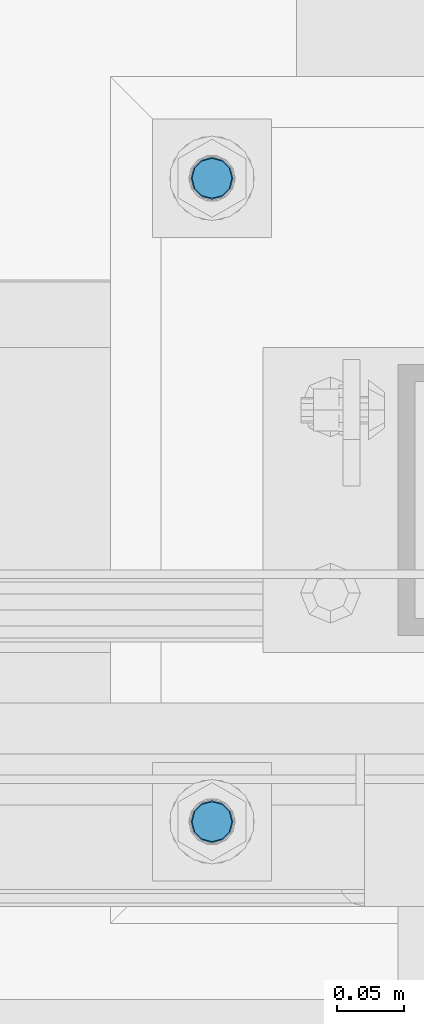
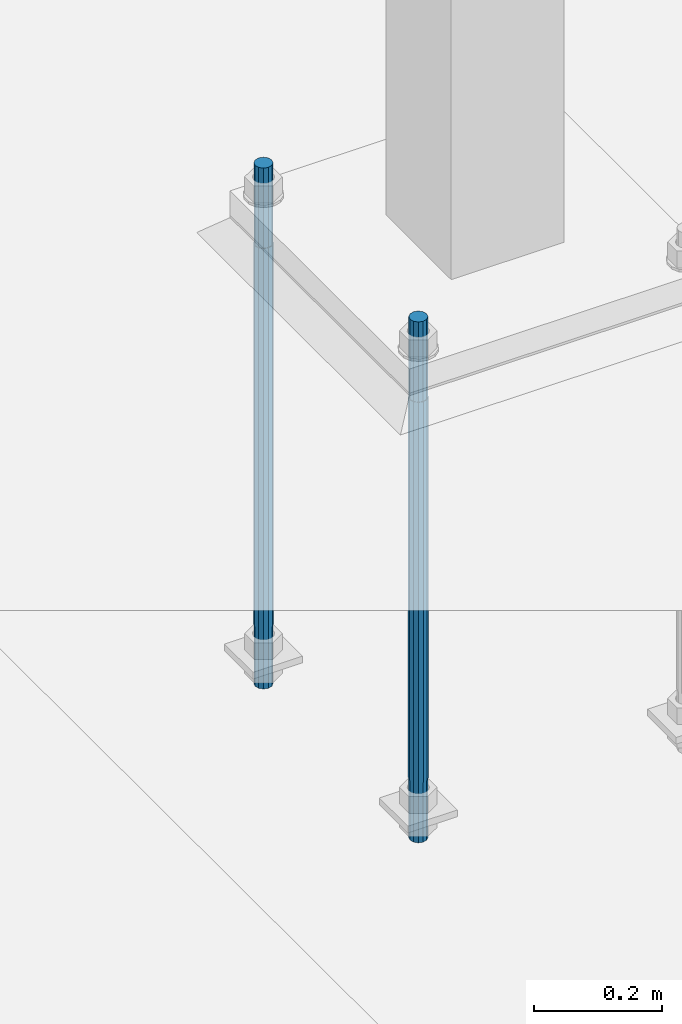
# One storey, part 819 of 1876: 2 columns, 1 element without a shape of its own.
"""IFC2X3 building model written with IfcOpenShell, lengths in millimetres."""

from ifc_helpers import new_model, si_unit, frame, origin_with_axes, place, context, subcontext, project, spatial, faceted_brep, material, type_object, element, aggregate, save


model = new_model("IFC2X3")

# Units and contexts
model_context = context("Model", 3, precision=1e-05, world=origin_with_axes())
body_context = subcontext(model_context, "Body", "Model", "MODEL_VIEW")
ifc_project = project(units=[si_unit("LENGTHUNIT", "METRE", prefix="MILLI"), si_unit("AREAUNIT", "SQUARE_METRE"), si_unit("VOLUMEUNIT", "CUBIC_METRE"), si_unit("MASSUNIT", "GRAM", prefix="KILO"), si_unit("TIMEUNIT", "SECOND"), si_unit("PLANEANGLEUNIT", "RADIAN"), si_unit("SOLIDANGLEUNIT", "STERADIAN"), si_unit("THERMODYNAMICTEMPERATUREUNIT", "DEGREE_CELSIUS"), si_unit("LUMINOUSINTENSITYUNIT", "LUMEN")], contexts=[model_context])

# Site, building, storey
site_placement = place(None, origin_with_axes())
site = spatial("IfcSite", under=ifc_project, at=site_placement, CompositionType="ELEMENT")
building_placement = place(site_placement, origin_with_axes())
building = spatial("IfcBuilding", under=site, at=building_placement, Name="Undefined", CompositionType="ELEMENT")
storey_placement = place(building_placement, origin_with_axes())
storey = spatial("IfcBuildingStorey", under=building, at=storey_placement, Name="Undefined", CompositionType="ELEMENT", Elevation=0.0)

# Assembly, columns
assembly_placement = place(storey_placement, origin_with_axes())
assembly = element("IfcElementAssembly", 1, at=assembly_placement, inside=storey, Name="TEMPLATE", AssemblyPlace="NOTDEFINED", PredefinedType="RIGID_FRAME")
ifc_material = material(Name="STEEL/F1554-GR.55")
column_type = type_object("IfcColumnType", PredefinedType="NOTDEFINED")
column_1_placement = place(assembly_placement, frame((1485.9, -4813.3, 0.0), z_axis=(1.0, 0.0, 0.0), x_axis=(0.0, 0.0, -1.0)))
column_1 = element("IfcColumn", 2, at=column_1_placement, type_object=column_type, material=ifc_material, Name="ANCHOR_BOLTS", context=body_context, shape_type="Brep", body=[
    faceted_brep([(-152.4, -12.9903810567666, 7.5), (-152.4, -7.5, 12.9903810567666), (-152.4, 0.0, 15.0), (-152.4, 7.5, 12.9903810567666), (-152.4, 12.9903810567666, 7.5), (-152.4, 15.0, 0.0), (-152.4, 12.9903810567666, -7.5), (-152.4, 7.5, -12.9903810567666), (-152.4, 0.0, -15.0), (-152.4, -7.5, -12.9903810567666), (-152.4, -12.9903810567666, -7.5), (-152.4, -15.0, 0.0), (0.0, 15.0, 0.0), (0.0, 12.9903810567666, -7.5), (0.0, 7.5, -12.9903810567666), (0.0, 0.0, -15.0), (0.0, -7.5, -12.9903810567666), (0.0, -12.9903810567666, -7.5), (0.0, -15.0, 0.0), (0.0, -12.9903810567666, 7.5), (0.0, -7.5, 12.9903810567666), (0.0, 0.0, 15.0), (0.0, 7.5, 12.9903810567666), (0.0, 12.9903810567666, 7.5), (0.0, -13.7481532850779, 7.9375), (0.0, -7.9375, 13.7481532850798), (0.0, 0.0, 15.875), (0.0, 7.9375, 13.7481532850798), (0.0, 13.7481532850779, 7.9375), (0.0, 15.875, 0.0), (0.0, 13.7481532850779, -7.9375), (0.0, 7.9375, -13.7481532850798), (0.0, 0.0, -15.875), (0.0, -7.9375, -13.7481532850798), (0.0, -13.7481532850779, -7.9375), (0.0, -15.875, 0.0), (723.9, -15.875, 0.0), (723.9, -13.7481532850779, 7.9375), (723.9, -7.9375, 13.7481532850779), (723.9, 0.0, 15.875), (723.9, 7.9375, 13.7481532850779), (723.9, 13.7481532850779, 7.9375), (723.9, 15.875, 0.0), (723.9, 13.7481532850779, -7.9375), (723.9, 7.9375, -13.7481532850779), (723.9, 0.0, -15.875), (723.9, -7.9375, -13.7481532850779), (723.9, -13.7481532850779, -7.9375), (723.9, -7.5, 12.9903810567666), (723.9, 0.0, 15.0), (723.9, 7.5, 12.9903810567666), (723.9, 12.9903810567666, 7.5), (723.9, 15.0, 0.0), (723.9, 12.9903810567666, -7.5), (723.9, 7.5, -12.9903810567666), (723.9, 0.0, -15.0), (723.9, -7.5, -12.9903810567666), (723.9, -12.9903810567666, -7.5), (723.9, -15.0, 0.0), (723.9, -12.9903810567666, 7.5), (838.2, -7.5, -12.9903810567666), (838.2, 0.0, -15.0), (838.2, 7.5, -12.9903810567666), (838.2, 12.9903810567666, -7.5), (838.2, 15.0, 0.0), (838.2, 12.9903810567666, 7.5), (838.2, 7.5, 12.9903810567666), (838.2, 0.0, 15.0), (838.2, -7.5, 12.9903810567666), (838.2, -12.9903810567666, 7.5), (838.2, -15.0, 0.0), (838.2, -12.9903810567666, -7.5)], [[[0, 1, 2, 3, 4, 5, 6, 7, 8, 9, 10, 11]], [[6, 5, 12, 13]], [[7, 6, 13, 14]], [[8, 7, 14, 15]], [[9, 8, 15, 16]], [[10, 9, 16, 17]], [[11, 10, 17, 18]], [[0, 11, 18, 19]], [[1, 0, 19, 20]], [[2, 1, 20, 21]], [[3, 2, 21, 22]], [[4, 3, 22, 23]], [[5, 4, 23, 12]], [[24, 25, 26, 27, 28, 29, 30, 31, 32, 33, 34, 35], [22, 21, 20, 19, 18, 17, 16, 15, 14, 13, 12, 23]], [[24, 35, 36, 37]], [[25, 24, 37, 38]], [[26, 25, 38, 39]], [[27, 26, 39, 40]], [[28, 27, 40, 41]], [[29, 28, 41, 42]], [[30, 29, 42, 43]], [[31, 30, 43, 44]], [[32, 31, 44, 45]], [[33, 32, 45, 46]], [[34, 33, 46, 47]], [[35, 34, 47, 36]], [[46, 45, 44, 43, 42, 41, 40, 39, 38, 37, 36, 47], [48, 49, 50, 51, 52, 53, 54, 55, 56, 57, 58, 59]], [[60, 61, 62, 63, 64, 65, 66, 67, 68, 69, 70, 71]], [[68, 67, 49, 48]], [[69, 68, 48, 59]], [[70, 69, 59, 58]], [[71, 70, 58, 57]], [[60, 71, 57, 56]], [[61, 60, 56, 55]], [[62, 61, 55, 54]], [[63, 62, 54, 53]], [[64, 63, 53, 52]], [[65, 64, 52, 51]], [[66, 65, 51, 50]], [[67, 66, 50, 49]]]),
])
column_2_placement = place(assembly_placement, frame((1485.9, -4330.7, 0.0), z_axis=(-1.0, 0.0, 0.0), x_axis=(0.0, 0.0, -1.0)))
column_2 = element("IfcColumn", 3, at=column_2_placement, type_object=column_type, material=ifc_material, Name="ANCHOR_BOLTS", context=body_context, shape_type="Brep", body=[
    faceted_brep([(-152.4, -12.9903810567666, 7.5), (-152.4, -7.5, 12.9903810567666), (-152.4, 0.0, 15.0), (-152.4, 7.5, 12.9903810567666), (-152.4, 12.9903810567666, 7.5), (-152.4, 15.0, 0.0), (-152.4, 12.9903810567666, -7.5), (-152.4, 7.5, -12.9903810567666), (-152.4, 0.0, -15.0), (-152.4, -7.5, -12.9903810567666), (-152.4, -12.9903810567666, -7.5), (-152.4, -15.0, 0.0), (0.0, 15.0, 0.0), (0.0, 12.9903810567666, -7.5), (0.0, 7.5, -12.9903810567666), (0.0, 0.0, -15.0), (0.0, -7.5, -12.9903810567666), (0.0, -12.9903810567666, -7.5), (0.0, -15.0, 0.0), (0.0, -12.9903810567666, 7.5), (0.0, -7.5, 12.9903810567666), (0.0, 0.0, 15.0), (0.0, 7.5, 12.9903810567666), (0.0, 12.9903810567666, 7.5), (0.0, -13.7481532850779, 7.9375), (0.0, -7.9375, 13.7481532850798), (0.0, 0.0, 15.875), (0.0, 7.9375, 13.7481532850798), (0.0, 13.7481532850779, 7.9375), (0.0, 15.875, 0.0), (0.0, 13.7481532850779, -7.9375), (0.0, 7.9375, -13.7481532850798), (0.0, 0.0, -15.875), (0.0, -7.9375, -13.7481532850798), (0.0, -13.7481532850779, -7.9375), (0.0, -15.875, 0.0), (723.9, -15.875, 0.0), (723.9, -13.7481532850779, 7.9375), (723.9, -7.9375, 13.7481532850779), (723.9, 0.0, 15.875), (723.9, 7.9375, 13.7481532850779), (723.9, 13.7481532850779, 7.9375), (723.9, 15.875, 0.0), (723.9, 13.7481532850779, -7.9375), (723.9, 7.9375, -13.7481532850779), (723.9, 0.0, -15.875), (723.9, -7.9375, -13.7481532850779), (723.9, -13.7481532850779, -7.9375), (723.9, -7.5, 12.9903810567666), (723.9, 0.0, 15.0), (723.9, 7.5, 12.9903810567666), (723.9, 12.9903810567666, 7.5), (723.9, 15.0, 0.0), (723.9, 12.9903810567666, -7.5), (723.9, 7.5, -12.9903810567666), (723.9, 0.0, -15.0), (723.9, -7.5, -12.9903810567666), (723.9, -12.9903810567666, -7.5), (723.9, -15.0, 0.0), (723.9, -12.9903810567666, 7.5), (838.2, -7.5, -12.9903810567666), (838.2, 0.0, -15.0), (838.2, 7.5, -12.9903810567666), (838.2, 12.9903810567666, -7.5), (838.2, 15.0, 0.0), (838.2, 12.9903810567666, 7.5), (838.2, 7.5, 12.9903810567666), (838.2, 0.0, 15.0), (838.2, -7.5, 12.9903810567666), (838.2, -12.9903810567666, 7.5), (838.2, -15.0, 0.0), (838.2, -12.9903810567666, -7.5)], [[[0, 1, 2, 3, 4, 5, 6, 7, 8, 9, 10, 11]], [[6, 5, 12, 13]], [[7, 6, 13, 14]], [[8, 7, 14, 15]], [[9, 8, 15, 16]], [[10, 9, 16, 17]], [[11, 10, 17, 18]], [[0, 11, 18, 19]], [[1, 0, 19, 20]], [[2, 1, 20, 21]], [[3, 2, 21, 22]], [[4, 3, 22, 23]], [[5, 4, 23, 12]], [[24, 25, 26, 27, 28, 29, 30, 31, 32, 33, 34, 35], [22, 21, 20, 19, 18, 17, 16, 15, 14, 13, 12, 23]], [[24, 35, 36, 37]], [[25, 24, 37, 38]], [[26, 25, 38, 39]], [[27, 26, 39, 40]], [[28, 27, 40, 41]], [[29, 28, 41, 42]], [[30, 29, 42, 43]], [[31, 30, 43, 44]], [[32, 31, 44, 45]], [[33, 32, 45, 46]], [[34, 33, 46, 47]], [[35, 34, 47, 36]], [[46, 45, 44, 43, 42, 41, 40, 39, 38, 37, 36, 47], [48, 49, 50, 51, 52, 53, 54, 55, 56, 57, 58, 59]], [[60, 61, 62, 63, 64, 65, 66, 67, 68, 69, 70, 71]], [[68, 67, 49, 48]], [[69, 68, 48, 59]], [[70, 69, 59, 58]], [[71, 70, 58, 57]], [[60, 71, 57, 56]], [[61, 60, 56, 55]], [[62, 61, 55, 54]], [[63, 62, 54, 53]], [[64, 63, 53, 52]], [[65, 64, 52, 51]], [[66, 65, 51, 50]], [[67, 66, 50, 49]]]),
])
aggregate(assembly, [column_1, column_2])

save(model, "model.ifc")
